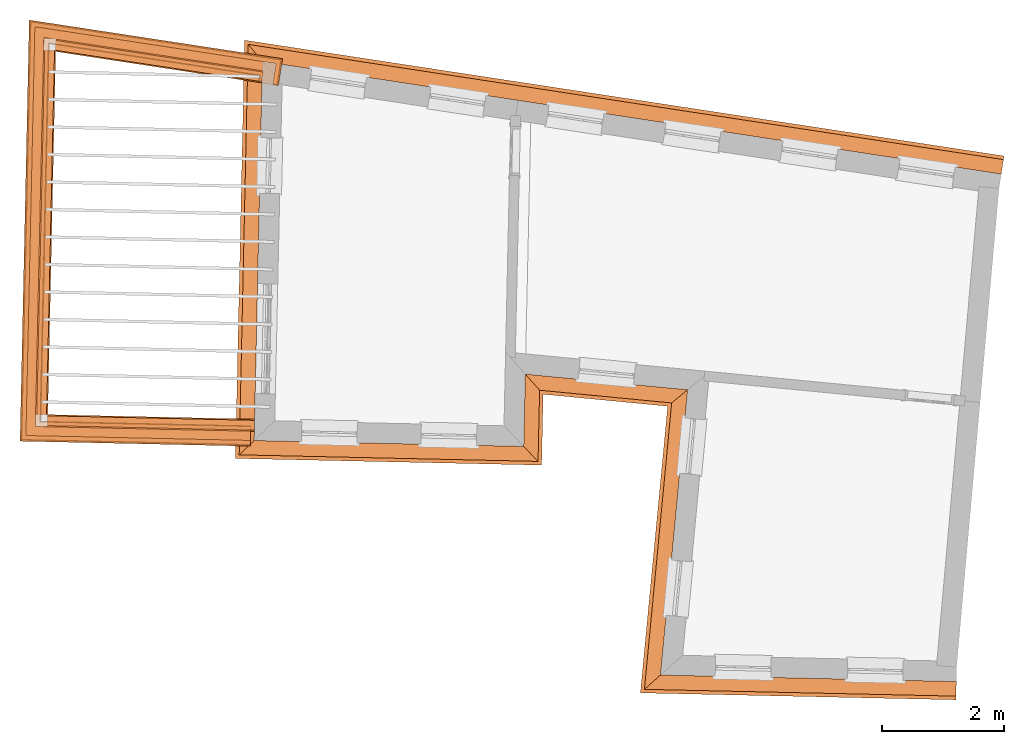
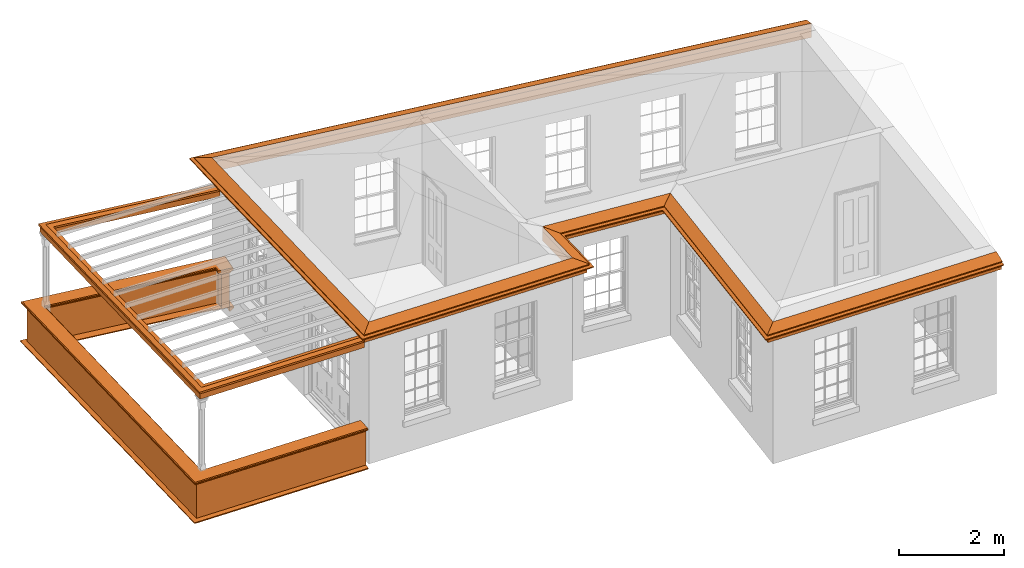
# One storey, part 11 of 12: 7 proxies.
"""IFC2X3 building model written with IfcOpenShell, lengths in metres."""

from ifc_helpers import new_model, entity, si_unit, frame, origin, place, context, subcontext, project, spatial, element, save


model = new_model("IFC2X3")

# Units and contexts
model_context = context("Model", 3, world=origin())
body_context = subcontext(model_context, "Body", "Model", "MODEL_VIEW")
ifc_project = project(units=[si_unit("PLANEANGLEUNIT", "RADIAN"), si_unit("MASSUNIT", "GRAM", prefix="KILO"), si_unit("FORCEUNIT", "NEWTON", prefix="KILO"), si_unit("LENGTHUNIT", "METRE")], contexts=[model_context])

# Site, building, storey
site_placement = place(None, origin())
site = spatial("IfcSite", under=ifc_project, at=site_placement, CompositionType="ELEMENT")
building_placement = place(None, origin())
building = spatial("IfcBuilding", under=site, at=building_placement, Name="Building plot-18", CompositionType="ELEMENT")
storey_placement = place(None, frame((0.0, 0.0, 9.9)))
storey = spatial("IfcBuildingStorey", under=building, at=storey_placement, Name="Floor 2", CompositionType="ELEMENT", Elevation=9.9)

# Proxies
proxy_1_placement = place(storey_placement, frame((0.0, 0.0, 3.3)))
axis2_placement3_d_1 = entity("IfcAxis2Placement3D", entity("IfcCartesianPoint", [0.0, 0.0, 0.0]))
element("IfcBuildingElementProxy", 1, at=proxy_1_placement, inside=storey, Name="eaves", CompositionType="ELEMENT", context=body_context, shape_type="SweptSolid", held_by="IfcProductRepresentation", body=[
    entity("IfcSurfaceCurveSweptAreaSolid", entity("IfcArbitraryClosedProfileDef", "AREA", None, entity("IfcPolyline", [entity("IfcCartesianPoint", [-0.11, 0.25]), entity("IfcCartesianPoint", [-0.33, 0.25]), entity("IfcCartesianPoint", [-0.33, 0.265]), entity("IfcCartesianPoint", [-0.318, 0.268]), entity("IfcCartesianPoint", [-0.309, 0.274]), entity("IfcCartesianPoint", [-0.303, 0.283]), entity("IfcCartesianPoint", [-0.3, 0.295]), entity("IfcCartesianPoint", [-0.285, 0.295]), entity("IfcCartesianPoint", [-0.285, 0.455]), entity("IfcCartesianPoint", [-0.205, 0.455]), entity("IfcCartesianPoint", [-0.205, 0.47]), entity("IfcCartesianPoint", [-0.19, 0.47]), entity("IfcCartesianPoint", [-0.189, 0.483]), entity("IfcCartesianPoint", [-0.186, 0.494]), entity("IfcCartesianPoint", [-0.179, 0.506]), entity("IfcCartesianPoint", [-0.17, 0.514]), entity("IfcCartesianPoint", [-0.16, 0.52]), entity("IfcCartesianPoint", [-0.149, 0.529]), entity("IfcCartesianPoint", [-0.143, 0.539]), entity("IfcCartesianPoint", [-0.14, 0.55]), entity("IfcCartesianPoint", [-0.12, 0.55]), entity("IfcCartesianPoint", [-0.11, 0.48]), entity("IfcCartesianPoint", [-0.11, 0.25])])), axis2_placement3_d_1, entity("IfcPolyline", [entity("IfcCartesianPoint", [101.953834636175, 24.5180983350628]), entity("IfcCartesianPoint", [90.1480265405749, 26.3182821833703]), entity("IfcCartesianPoint", [90.0240656426027, 20.6507996603855]), entity("IfcCartesianPoint", [93.9339826517031, 20.5652807688001]), entity("IfcCartesianPoint", [93.960270454657, 21.7671570559657]), entity("IfcCartesianPoint", [97.1337433890627, 21.4617038787411]), entity("IfcCartesianPoint", [96.6914323726844, 16.8135830470463]), entity("IfcCartesianPoint", [101.262332225262, 16.7136069380828])]), 0.0, 1.0, entity("IfcPlane", axis2_placement3_d_1)),
])
proxy_2_placement = place(storey_placement, frame((0.0, 0.0, 3.3)))
axis2_placement3_d_2 = entity("IfcAxis2Placement3D", entity("IfcCartesianPoint", [0.0, 0.0, 0.0]))
element("IfcBuildingElementProxy", 2, at=proxy_2_placement, inside=storey, Name="eaves", CompositionType="ELEMENT", context=body_context, shape_type="SweptSolid", held_by="IfcProductRepresentation", body=[
    entity("IfcSurfaceCurveSweptAreaSolid", entity("IfcArbitraryClosedProfileDef", "AREA", None, entity("IfcPolyline", [entity("IfcCartesianPoint", [-0.11, 0.25]), entity("IfcCartesianPoint", [-0.11, 0.48]), entity("IfcCartesianPoint", [-0.08, 0.49]), entity("IfcCartesianPoint", [0.0, 0.25]), entity("IfcCartesianPoint", [-0.11, 0.25])])), axis2_placement3_d_2, entity("IfcPolyline", [entity("IfcCartesianPoint", [101.953834636175, 24.5180983350628]), entity("IfcCartesianPoint", [90.1480265405749, 26.3182821833703]), entity("IfcCartesianPoint", [90.0240656426027, 20.6507996603855]), entity("IfcCartesianPoint", [93.9339826517031, 20.5652807688001]), entity("IfcCartesianPoint", [93.960270454657, 21.7671570559657]), entity("IfcCartesianPoint", [97.1337433890627, 21.4617038787411]), entity("IfcCartesianPoint", [96.6914323726844, 16.8135830470463]), entity("IfcCartesianPoint", [101.262332225262, 16.7136069380828])]), 0.0, 1.0, entity("IfcPlane", axis2_placement3_d_2)),
])
proxy_3_placement = place(storey_placement, origin())
axis2_placement3_d_3 = entity("IfcAxis2Placement3D", entity("IfcCartesianPoint", [0.0, 0.0, 0.0]))
element("IfcBuildingElementProxy", 3, at=proxy_3_placement, inside=storey, Name="parapet", CompositionType="ELEMENT", context=body_context, shape_type="SweptSolid", held_by="IfcProductRepresentation", body=[
    entity("IfcSurfaceCurveSweptAreaSolid", entity("IfcArbitraryClosedProfileDef", "AREA", None, entity("IfcPolyline", [entity("IfcCartesianPoint", [0.0, 0.25]), entity("IfcCartesianPoint", [0.795, 0.25]), entity("IfcCartesianPoint", [0.795, 0.09]), entity("IfcCartesianPoint", [0.02, 0.09]), entity("IfcCartesianPoint", [0.02, -0.08]), entity("IfcCartesianPoint", [0.0, -0.08]), entity("IfcCartesianPoint", [0.0, 0.25])])), axis2_placement3_d_3, entity("IfcPolyline", [entity("IfcCartesianPoint", [89.8264947451352, 26.2661544122562]), entity("IfcCartesianPoint", [89.8415687983855, 26.3650117484463]), entity("IfcCartesianPoint", [86.4243044612267, 26.8860861226302]), entity("IfcCartesianPoint", [86.2897108897328, 20.7324786010148]), entity("IfcCartesianPoint", [89.7141397676454, 20.6575784531932])]), 0.0, 1.0, entity("IfcPlane", axis2_placement3_d_3)),
])
proxy_4_placement = place(storey_placement, origin())
axis2_placement3_d_4 = entity("IfcAxis2Placement3D", entity("IfcCartesianPoint", [0.0, 0.0, 0.0]))
element("IfcBuildingElementProxy", 4, at=proxy_4_placement, inside=storey, Name="parapet", CompositionType="ELEMENT", context=body_context, shape_type="SweptSolid", held_by="IfcProductRepresentation", body=[
    entity("IfcSurfaceCurveSweptAreaSolid", entity("IfcArbitraryClosedProfileDef", "AREA", None, entity("IfcPolyline", [entity("IfcCartesianPoint", [0.795, 0.265]), entity("IfcCartesianPoint", [0.807, 0.268]), entity("IfcCartesianPoint", [0.816, 0.274]), entity("IfcCartesianPoint", [0.822, 0.283]), entity("IfcCartesianPoint", [0.825, 0.295]), entity("IfcCartesianPoint", [0.84, 0.295]), entity("IfcCartesianPoint", [0.84, 0.305]), entity("IfcCartesianPoint", [0.842, 0.317]), entity("IfcCartesianPoint", [0.849, 0.326]), entity("IfcCartesianPoint", [0.858, 0.333]), entity("IfcCartesianPoint", [0.87, 0.335]), entity("IfcCartesianPoint", [0.882, 0.333]), entity("IfcCartesianPoint", [0.891, 0.326]), entity("IfcCartesianPoint", [0.898, 0.317]), entity("IfcCartesianPoint", [0.9, 0.305]), entity("IfcCartesianPoint", [0.9, 0.035]), entity("IfcCartesianPoint", [0.898, 0.023]), entity("IfcCartesianPoint", [0.891, 0.014]), entity("IfcCartesianPoint", [0.882, 0.007]), entity("IfcCartesianPoint", [0.87, 0.005]), entity("IfcCartesianPoint", [0.858, 0.007]), entity("IfcCartesianPoint", [0.849, 0.014]), entity("IfcCartesianPoint", [0.842, 0.023]), entity("IfcCartesianPoint", [0.84, 0.035]), entity("IfcCartesianPoint", [0.84, 0.045]), entity("IfcCartesianPoint", [0.825, 0.045]), entity("IfcCartesianPoint", [0.822, 0.057]), entity("IfcCartesianPoint", [0.816, 0.066]), entity("IfcCartesianPoint", [0.807, 0.072]), entity("IfcCartesianPoint", [0.795, 0.075]), entity("IfcCartesianPoint", [0.795, 0.265])])), axis2_placement3_d_4, entity("IfcPolyline", [entity("IfcCartesianPoint", [89.8264947451352, 26.2661544122562]), entity("IfcCartesianPoint", [89.8415687983855, 26.3650117484463]), entity("IfcCartesianPoint", [86.4243044612267, 26.8860861226302]), entity("IfcCartesianPoint", [86.2897108897328, 20.7324786010148]), entity("IfcCartesianPoint", [89.7141397676454, 20.6575784531932])]), 0.0, 1.0, entity("IfcPlane", axis2_placement3_d_4)),
])
proxy_5_placement = place(storey_placement, origin())
axis2_placement3_d_5 = entity("IfcAxis2Placement3D", entity("IfcCartesianPoint", [0.0, 0.0, 0.0]))
element("IfcBuildingElementProxy", 5, at=proxy_5_placement, inside=storey, Name="parapet", CompositionType="ELEMENT", context=body_context, shape_type="SweptSolid", held_by="IfcProductRepresentation", body=[
    entity("IfcSurfaceCurveSweptAreaSolid", entity("IfcArbitraryClosedProfileDef", "AREA", None, entity("IfcPolyline", [entity("IfcCartesianPoint", [-0.1, 0.25]), entity("IfcCartesianPoint", [-0.1, 0.265]), entity("IfcCartesianPoint", [-0.085, 0.265]), entity("IfcCartesianPoint", [-0.084, 0.278]), entity("IfcCartesianPoint", [-0.081, 0.289]), entity("IfcCartesianPoint", [-0.074, 0.301]), entity("IfcCartesianPoint", [-0.065, 0.309]), entity("IfcCartesianPoint", [-0.055, 0.315]), entity("IfcCartesianPoint", [-0.044, 0.324]), entity("IfcCartesianPoint", [-0.038, 0.334]), entity("IfcCartesianPoint", [-0.035, 0.345]), entity("IfcCartesianPoint", [-0.015, 0.345]), entity("IfcCartesianPoint", [0.0, 0.25]), entity("IfcCartesianPoint", [-0.1, 0.25])])), axis2_placement3_d_5, entity("IfcPolyline", [entity("IfcCartesianPoint", [89.8264947451352, 26.2661544122562]), entity("IfcCartesianPoint", [89.8415687983855, 26.3650117484463]), entity("IfcCartesianPoint", [86.4243044612267, 26.8860861226302]), entity("IfcCartesianPoint", [86.2897108897328, 20.7324786010148]), entity("IfcCartesianPoint", [89.7141397676454, 20.6575784531932])]), 0.0, 1.0, entity("IfcPlane", axis2_placement3_d_5)),
])
proxy_6_placement = place(storey_placement, frame((0.0, 0.0, 3.3)))
axis2_placement3_d_6 = entity("IfcAxis2Placement3D", entity("IfcCartesianPoint", [0.0, 0.0, 0.0]))
element("IfcBuildingElementProxy", 6, at=proxy_6_placement, inside=storey, Name="pergola beam", CompositionType="ELEMENT", context=body_context, shape_type="SweptSolid", held_by="IfcProductRepresentation", body=[
    entity("IfcSurfaceCurveSweptAreaSolid", entity("IfcArbitraryClosedProfileDef", "AREA", None, entity("IfcPolyline", [entity("IfcCartesianPoint", [-0.7, -0.08]), entity("IfcCartesianPoint", [-0.7, 0.08]), entity("IfcCartesianPoint", [-0.56, 0.08]), entity("IfcCartesianPoint", [-0.56, -0.08]), entity("IfcCartesianPoint", [-0.7, -0.08])])), axis2_placement3_d_6, entity("IfcPolyline", [entity("IfcCartesianPoint", [89.9008832000996, 26.3559673164961]), entity("IfcCartesianPoint", [86.4243044612267, 26.8860861226302]), entity("IfcCartesianPoint", [86.2897108897328, 20.7324786010148]), entity("IfcCartesianPoint", [89.7741254208629, 20.6562664287788])]), 0.0, 1.0, entity("IfcPlane", axis2_placement3_d_6)),
])
proxy_7_placement = place(storey_placement, frame((0.0, 0.0, 3.3)))
axis2_placement3_d_7 = entity("IfcAxis2Placement3D", entity("IfcCartesianPoint", [0.0, 0.0, 0.0]))
element("IfcBuildingElementProxy", 7, at=proxy_7_placement, inside=storey, Name="pergola beam", CompositionType="ELEMENT", context=body_context, shape_type="SweptSolid", held_by="IfcProductRepresentation", body=[
    entity("IfcSurfaceCurveSweptAreaSolid", entity("IfcArbitraryClosedProfileDef", "AREA", None, entity("IfcPolyline", [entity("IfcCartesianPoint", [-0.5, 0.0]), entity("IfcCartesianPoint", [-0.52, -0.1]), entity("IfcCartesianPoint", [-0.56, -0.1]), entity("IfcCartesianPoint", [-0.56, 0.1]), entity("IfcCartesianPoint", [-0.52, 0.1]), entity("IfcCartesianPoint", [-0.5, 0.0])])), axis2_placement3_d_7, entity("IfcPolyline", [entity("IfcCartesianPoint", [89.9008832000996, 26.3559673164961]), entity("IfcCartesianPoint", [86.4243044612267, 26.8860861226302]), entity("IfcCartesianPoint", [86.2897108897328, 20.7324786010148]), entity("IfcCartesianPoint", [89.7741254208629, 20.6562664287788])]), 0.0, 1.0, entity("IfcPlane", axis2_placement3_d_7)),
])

save(model, "model.ifc")
